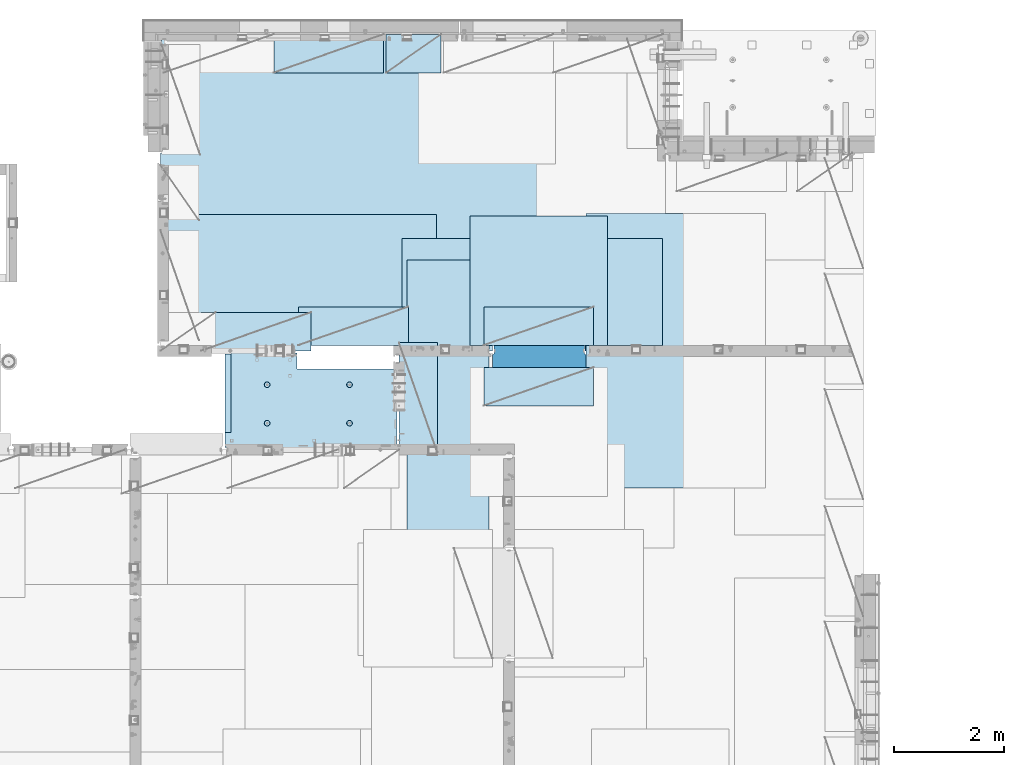
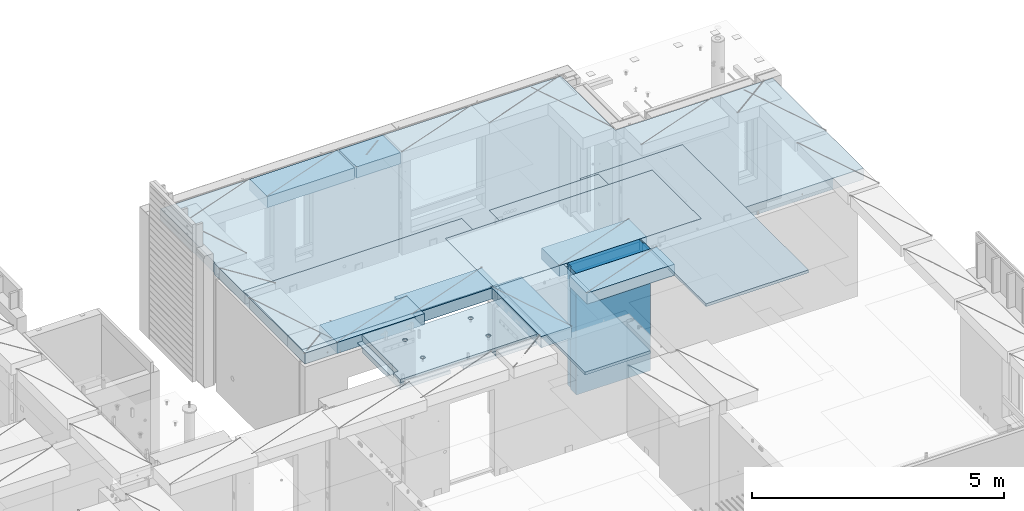
# One storey, part 178 of 309: 13 plates, 2 slabs, 14 elements without a shape of their own.
"""IFC2X3 building model written with IfcOpenShell, lengths in millimetres."""

from ifc_helpers import new_model, si_unit, frame, origin_with_axes, place, context, subcontext, project, spatial, faceted_brep, material, type_object, element, aggregate, save


model = new_model("IFC2X3")

# Units and contexts
model_context = context("Model", 3, precision=1e-05, world=origin_with_axes())
body_context = subcontext(model_context, "Body", "Model", "MODEL_VIEW")
ifc_project = project(units=[si_unit("LENGTHUNIT", "METRE", prefix="MILLI"), si_unit("AREAUNIT", "SQUARE_METRE"), si_unit("VOLUMEUNIT", "CUBIC_METRE"), si_unit("MASSUNIT", "GRAM", prefix="KILO"), si_unit("TIMEUNIT", "SECOND"), si_unit("PLANEANGLEUNIT", "RADIAN"), si_unit("SOLIDANGLEUNIT", "STERADIAN"), si_unit("THERMODYNAMICTEMPERATUREUNIT", "DEGREE_CELSIUS"), si_unit("LUMINOUSINTENSITYUNIT", "LUMEN")], contexts=[model_context])

# Site, building, storey
site_placement = place(None, origin_with_axes())
site = spatial("IfcSite", under=ifc_project, at=site_placement, CompositionType="ELEMENT")
building_placement = place(site_placement, origin_with_axes())
building = spatial("IfcBuilding", under=site, at=building_placement, CompositionType="ELEMENT")
storey_placement = place(building_placement, origin_with_axes())
storey = spatial("IfcBuildingStorey", under=building, at=storey_placement, Name="7", CompositionType="ELEMENT", Elevation=0.0)

# Assembly, slab
assembly_1_placement = place(storey_placement, origin_with_axes())
assembly_1 = element("IfcElementAssembly", 1, at=assembly_1_placement, inside=storey, AssemblyPlace="NOTDEFINED", PredefinedType="REINFORCEMENT_UNIT")
ifc_material_1 = material(Name="CONCRETE/C25/30")
slab_type_1 = type_object("IfcSlabType", PredefinedType="NOTDEFINED")
slab_1_placement = place(assembly_1_placement, frame((26570.0059390845, 15220.0026483125, 102620.0), z_axis=(-0.999999999997437, -2.26400000064461e-06, 0.0), x_axis=(-1.19799915409591e-06, 0.999999999999282, 0.0)))
slab_1 = element("IfcSlab", 2, at=slab_1_placement, type_object=slab_type_1, material=ifc_material_1, PredefinedType="FLOOR", context=body_context, shape_type="Brep", body=[
    faceted_brep([(260.000036693442, 30.0, 20.0001116859203), (260.00040878505, 30.0, 210.00282380305), (760.000392750888, 30.0, 210.001882803081), (760.000035167954, 30.0, 20.0003241859195), (259.999997532928, 50.0008466322761, 0.000110715616756352), (259.999997531775, 130.0, 4.72937244921923e-11), (260.00040878505, 130.0, 210.00282380305), (260.00003669344, 50.0008466322906, 20.0001116859239), (760.000392750888, 130.0, 210.001882803081), (759.999997530887, 50.0009701322706, 0.00188280345173553), (760.000035167954, 50.0009701322851, 20.0003241859267), (759.999997530887, 130.0, 1.4915713109076e-10), (0.0, 130.0, -1.81898940354586e-12), (0.0, 50.0007830199902, -3.63797880709171e-12), (2.23492861550767e-06, 50.0007830199902, 20.0000012144774), (0.00314200731554592, 50.0009709416772, 1679.99820316408), (0.00316042736994859, 130.0, 1679.99820316404), (20.0042037197236, 50.0007871208509, 20.0000019346335), (20.0050448999082, 50.0009732451872, 1679.9981655205), (20.0051981998968, 30.0, 1979.99816552074), (210.003723882246, 30.0, 1979.99780794351), (210.003159282247, 30.0, 1679.99780794404), (20.0050448999027, 30.0, 1679.9981655205), (20.0057858500695, 50.0011356208415, 3129.99855788155), (0.00588817475545511, 50.0011356208415, 3129.99536132812), (0.00371018100122456, 50.0010050132987, 1979.99820316354), (20.0051981998986, 50.0010068401461, 1979.99816552074), (0.0, -49.9992169800098, -3.63797880709171e-12), (0.0, -130.0, -3.63797880709171e-12), (0.00588817475545511, -130.0, 3129.99536132812), (0.00588817475545511, -49.9988643791585, 3129.99536132812), (2.27349282795331e-05, -49.9992169800098, 20.000001214441), (1700.00578510373, 9.99999999994179, 3129.99536132812), (270.007324709519, 9.99999999994179, 3129.99536132812), (270.007273993393, 9.99999999994179, 3014.99280776216), (1700.0058891816, 9.99999999994179, 3014.99217713277), (1700.00588013352, 9.99999999994179, 3024.99005271558), (270.007273993393, -130.000000000058, 3014.99280776216), (270.007324709519, -130.0, 3129.99536132812), (1720.00727399273, -130.000000000058, 3014.99216831216), (1720.00727399273, -49.9988643791585, 3014.99216831216), (1700.0058891816, -49.9988643791585, 3014.99217713277), (1720.00696350816, 50.0011356208415, 1820.00270203459), (1720.00507313573, 130.0, 1820.00270203815), (1720.00548380367, 130.0, 2629.9953613439), (1720.00479630696, 50.0011356208415, 2629.99536134425), (1700.00697064704, 50.0011356208415, 1820.00273967458), (1700.00623760369, 50.0011356208415, 2629.99539898154), (1700.00697064704, -49.9988643791585, 1820.00273967458), (1700.00623760369, 30.0, 2629.99539898154), (1700.00578510373, 30.0, 3129.99535793147), (1510.00479630733, 130.0, 2629.99575656425), (1510.00479630733, 30.0, 2629.99575656425), (1510.00573730659, 130.0, 3129.99536132812), (1510.00573730659, 30.0, 3129.99536134176), (0.00588817475545511, 130.0, 3129.99536132812), (20.0057858500695, -49.9988643791585, 3129.99855788155), (0.00372479000361636, 130.0, 1979.99820316351), (210.003723882246, 130.0, 1979.99780794351), (210.003159282247, 130.0, 1679.99780794404), (20.0042037196527, -49.9988643791585, 20.0000019345935), (20.0041864226587, -49.9992128791491, 7.34271452529356e-07), (1429.99419217423, -49.9988643791585, 20.0006089333838), (1429.99420067423, -49.9988643791585, 0.000608933383773547), (1429.99735169022, -130.0, 7.40013310860377e-05), (458.262860973307, -110.000000000015, 813.90255309167), (472.201273869185, -110.000000000015, 821.004529187678), (483.262860973307, -110.000000000015, 832.066116291804), (490.364837069317, -110.000000000015, 846.004529187678), (492.812011254558, -110.000000000015, 861.455378906427), (490.364837069317, -110.000000000015, 876.906228625172), (483.262860973307, -110.000000000015, 890.844641521049), (472.201273869185, -110.000000000015, 901.906228625176), (458.262860973306, -110.000000000015, 909.008204721184), (442.81201125456, -110.000000000015, 911.455378906427), (427.361161535811, -110.000000000015, 909.008204721184), (413.422748639936, -110.000000000015, 901.906228625176), (402.361161535813, -110.000000000015, 890.844641521046), (395.259185439802, -110.000000000015, 876.906228625176), (392.81201125456, -110.000000000015, 861.455378906427), (395.259185439802, -110.000000000015, 846.004529187681), (402.361161535813, -110.000000000015, 832.0661162918), (413.422748639936, -110.000000000015, 821.004529187678), (427.361161535813, -110.000000000015, 813.90255309167), (442.812011254558, -110.000000000015, 811.455378906427), (458.965172324157, -130.0, 811.741061009179), (442.812011254558, -130.0, 809.182651633699), (473.537149442574, -130.0, 819.165854200462), (485.101535960521, -130.0, 830.730240718414), (492.526329151806, -130.0, 845.302217836826), (495.084738527285, -130.0, 861.45537890643), (492.526329151804, -130.0, 877.608539976027), (485.101535960521, -130.0, 892.180517094443), (473.537149442574, -130.0, 903.744903612387), (458.965172324157, -130.0, 911.16969680367), (442.81201125456, -130.0, 913.728106179151), (426.658850184962, -130.0, 911.169696803674), (412.086873066544, -130.0, 903.744903612391), (400.522486548598, -130.0, 892.180517094443), (393.097693357315, -130.0, 877.608539976027), (390.539283981834, -130.0, 861.455378906427), (393.097693357317, -130.0, 845.302217836826), (400.522486548598, -130.0, 830.730240718414), (412.086873066544, -130.0, 819.165854200462), (426.658850184962, -130.0, 811.741061009183), (1158.26361347154, -110.000000000058, 2313.90608356011), (1172.20202636741, -110.000000000058, 2321.00805965612), (1183.26361347154, -110.000000000058, 2332.06964676024), (1190.36558956755, -110.000000000058, 2346.00805965611), (1192.81276375279, -110.000000000058, 2361.45890937486), (1190.36558956755, -110.000000000058, 2376.90975909361), (1183.26361347154, -110.000000000058, 2390.84817198949), (1172.20202636741, -110.000000000058, 2401.90975909361), (1158.26361347154, -110.000000000058, 2409.01173518962), (1142.81276375279, -110.000000000058, 2411.45890937487), (1127.36191403404, -110.000000000058, 2409.01173518962), (1113.42350113817, -110.000000000058, 2401.90975909361), (1102.36191403404, -110.000000000058, 2390.84817198948), (1095.25993793803, -110.000000000058, 2376.90975909361), (1092.81276375279, -110.000000000058, 2361.45890937486), (1095.25993793803, -110.000000000058, 2346.00805965612), (1102.36191403404, -110.000000000058, 2332.06964676024), (1113.42350113817, -110.000000000058, 2321.00805965611), (1127.36191403405, -110.000000000058, 2313.90608356011), (1142.81276375279, -110.000000000058, 2311.45890937486), (1158.96592482239, -130.000000000044, 2311.74459147762), (1142.81276375279, -130.000000000044, 2309.18618210214), (1173.5379019408, -130.000000000044, 2319.1693846689), (1185.10228845875, -130.000000000044, 2330.73377118685), (1192.52708165004, -130.000000000044, 2345.30574830526), (1195.08549102551, -130.000000000044, 2361.45890937486), (1192.52708165004, -130.000000000044, 2377.61207044447), (1185.10228845875, -130.000000000044, 2392.18404756288), (1173.5379019408, -130.000000000044, 2403.74843408083), (1158.96592482239, -130.000000000044, 2411.17322727211), (1142.81276375279, -130.000000000044, 2413.73163664759), (1126.65960268319, -130.000000000044, 2411.17322727211), (1112.08762556478, -130.000000000044, 2403.74843408083), (1100.52323904683, -130.000000000044, 2392.18404756287), (1093.09844585554, -130.000000000044, 2377.61207044447), (1090.54003648007, -130.000000000044, 2361.45890937486), (1093.09844585555, -130.000000000044, 2345.30574830526), (1100.52323904683, -130.000000000044, 2330.73377118685), (1112.08762556478, -130.000000000044, 2319.1693846689), (1126.65960268319, -130.000000000044, 2311.74459147762), (1158.26322681425, -110.000000000029, 813.902566246979), (1172.20163971013, -110.000000000029, 821.004542342987), (1183.26322681425, -110.000000000029, 832.066129447114), (1190.36520291026, -110.000000000029, 846.004542342987), (1192.8123770955, -110.000000000029, 861.455392061736), (1190.36520291026, -110.000000000029, 876.906241780482), (1183.26322681425, -110.000000000029, 890.844654676363), (1172.20163971012, -110.000000000029, 901.906241780485), (1158.26322681425, -110.000000000029, 909.008217876493), (1142.8123770955, -110.000000000029, 911.455392061736), (1127.36152737675, -110.000000000029, 909.008217876493), (1113.42311448088, -110.000000000029, 901.906241780485), (1102.36152737675, -110.000000000029, 890.844654676359), (1095.25955128074, -110.000000000029, 876.906241780485), (1092.8123770955, -110.000000000029, 861.45539206174), (1095.25955128074, -110.000000000029, 846.004542342991), (1102.36152737675, -110.000000000029, 832.06612944711), (1113.42311448088, -110.000000000029, 821.004542342987), (1127.36152737675, -110.000000000029, 813.902566246979), (1142.8123770955, -110.000000000029, 811.455392061736), (1158.9655381651, -130.000000000029, 811.741074164489), (1142.8123770955, -130.000000000029, 809.182664789012), (1173.53751528352, -130.000000000029, 819.165867355772), (1185.10190180146, -130.000000000029, 830.730253873724), (1192.52669499275, -130.000000000029, 845.302230992136), (1195.08510436823, -130.000000000029, 861.45539206174), (1192.52669499275, -130.000000000029, 877.608553131337), (1185.10190180146, -130.000000000029, 892.180530249756), (1173.53751528351, -130.000000000029, 903.744916767697), (1158.9655381651, -130.000000000029, 911.16970995898), (1142.8123770955, -130.000000000029, 913.728119334461), (1126.6592160259, -130.000000000029, 911.169709958984), (1112.08723890749, -130.000000000029, 903.7449167677), (1100.52285238954, -130.000000000029, 892.180530249752), (1093.09805919825, -130.000000000029, 877.608553131337), (1090.53964982277, -130.000000000015, 861.455392061736), (1093.09805919826, -130.000000000015, 845.302230992136), (1100.52285238954, -130.000000000015, 830.730253873724), (1112.08723890749, -130.000000000015, 819.165867355776), (1126.6592160259, -130.000000000015, 811.741074164493), (458.263613472778, -110.000000000058, 2313.90740096011), (472.202026368655, -110.000000000058, 2321.00937705611), (483.263613472776, -110.000000000058, 2332.07096416024), (490.365589568788, -110.000000000058, 2346.00937705611), (492.812763754029, -110.000000000058, 2361.46022677486), (490.365589568788, -110.000000000058, 2376.91107649361), (483.263613472778, -110.000000000058, 2390.84948938949), (472.202026368655, -110.000000000058, 2401.91107649361), (458.263613472776, -110.000000000058, 2409.01305258962), (442.812763754029, -110.000000000058, 2411.46022677486), (427.361914035282, -110.000000000058, 2409.01305258962), (413.423501139407, -110.000000000058, 2401.91107649361), (402.361914035284, -110.000000000058, 2390.84948938949), (395.259937939272, -110.000000000058, 2376.91107649361), (392.812763754031, -110.000000000058, 2361.46022677486), (395.259937939272, -110.000000000058, 2346.00937705612), (402.361914035284, -110.000000000058, 2332.07096416024), (413.423501139407, -110.000000000058, 2321.00937705611), (427.361914035284, -110.000000000058, 2313.90740096011), (442.812763754029, -110.000000000058, 2311.46022677486), (458.965924823628, -130.000000000029, 2311.74590887762), (442.812763754029, -130.000000000029, 2309.18749950214), (473.537901942043, -130.000000000029, 2319.1707020689), (485.10228845999, -130.000000000029, 2330.73508858685), (492.527081651273, -130.000000000029, 2345.30706570526), (495.085491026754, -130.000000000029, 2361.46022677486), (492.527081651273, -130.000000000029, 2377.61338784446), (485.102288459992, -130.000000000029, 2392.18536496288), (473.537901942043, -130.000000000029, 2403.74975148082), (458.965924823628, -130.000000000029, 2411.1745446721), (442.812763754031, -130.000000000029, 2413.73295404758), (426.659602684433, -130.000000000029, 2411.17454467211), (412.087625566017, -130.000000000029, 2403.74975148082), (400.523239048071, -130.000000000029, 2392.18536496288), (393.098445856787, -130.000000000029, 2377.61338784446), (390.540036481307, -130.000000000029, 2361.46022677486), (393.098445856789, -130.000000000029, 2345.30706570526), (400.523239048067, -130.000000000029, 2330.73508858685), (412.087625566017, -130.000000000029, 2319.17070206891), (426.659602684433, -130.000000000029, 2311.74590887762), (1720.00603595581, -130.000000000029, 1820.00270203634), (1430.00077693619, -130.000000000044, 1820.00324782623), (1720.00719416424, -49.9988643791585, 1820.00270203415), (1430.00077693619, 129.999999999985, 1820.00324782623), (1429.99416747423, 50.0011356208415, 20.0006089334311), (1429.99417597423, 50.0011356208415, 0.000608933431067271), (1429.99735169022, 130.0, 2.80124368146062e-10), (20.0041864225386, 50.0007871208509, -3.03407432511449e-09)], [[[0, 1, 2, 3]], [[4, 5, 6, 1, 0, 7]], [[8, 2, 1, 6]], [[9, 10, 3, 2, 8, 11]], [[12, 13, 14, 15, 16]], [[14, 17, 18, 15]], [[19, 20, 21, 22]], [[23, 24, 25, 26]], [[27, 28, 29, 30, 31]], [[32, 33, 34, 35, 36]], [[37, 34, 33, 38]], [[35, 34, 37, 39, 40, 41]], [[42, 43, 44, 45]], [[46, 42, 45, 47]], [[32, 36, 35, 41, 48, 46, 47, 49, 50]], [[45, 44, 51, 52, 49, 47]], [[53, 54, 52, 51]], [[49, 52, 54, 50]], [[53, 55, 24, 23, 56, 30, 29, 38, 33, 32, 50, 54]], [[24, 55, 57, 25]], [[58, 20, 19, 26, 25, 57]], [[59, 21, 20, 58]], [[16, 15, 18, 22, 21, 59]], [[17, 60, 56, 23, 26, 19, 22, 18]], [[31, 30, 56, 60]], [[61, 27, 31, 60, 62, 63]], [[28, 27, 61, 63, 64]], [[65, 66, 67, 68, 69, 70, 71, 72, 73, 74, 75, 76, 77, 78, 79, 80, 81, 82, 83, 84]], [[85, 65, 84, 86]], [[87, 66, 65, 85]], [[88, 67, 66, 87]], [[89, 68, 67, 88]], [[90, 69, 68, 89]], [[91, 70, 69, 90]], [[92, 71, 70, 91]], [[93, 72, 71, 92]], [[94, 73, 72, 93]], [[95, 74, 73, 94]], [[96, 75, 74, 95]], [[97, 76, 75, 96]], [[98, 77, 76, 97]], [[99, 78, 77, 98]], [[100, 79, 78, 99]], [[101, 80, 79, 100]], [[102, 81, 80, 101]], [[103, 82, 81, 102]], [[104, 83, 82, 103]], [[86, 84, 83, 104]], [[105, 106, 107, 108, 109, 110, 111, 112, 113, 114, 115, 116, 117, 118, 119, 120, 121, 122, 123, 124]], [[125, 105, 124, 126]], [[127, 106, 105, 125]], [[128, 107, 106, 127]], [[129, 108, 107, 128]], [[130, 109, 108, 129]], [[131, 110, 109, 130]], [[132, 111, 110, 131]], [[133, 112, 111, 132]], [[134, 113, 112, 133]], [[135, 114, 113, 134]], [[136, 115, 114, 135]], [[137, 116, 115, 136]], [[138, 117, 116, 137]], [[139, 118, 117, 138]], [[140, 119, 118, 139]], [[141, 120, 119, 140]], [[142, 121, 120, 141]], [[143, 122, 121, 142]], [[144, 123, 122, 143]], [[126, 124, 123, 144]], [[145, 146, 147, 148, 149, 150, 151, 152, 153, 154, 155, 156, 157, 158, 159, 160, 161, 162, 163, 164]], [[165, 145, 164, 166]], [[167, 146, 145, 165]], [[168, 147, 146, 167]], [[169, 148, 147, 168]], [[170, 149, 148, 169]], [[171, 150, 149, 170]], [[172, 151, 150, 171]], [[173, 152, 151, 172]], [[174, 153, 152, 173]], [[175, 154, 153, 174]], [[176, 155, 154, 175]], [[177, 156, 155, 176]], [[178, 157, 156, 177]], [[179, 158, 157, 178]], [[180, 159, 158, 179]], [[181, 160, 159, 180]], [[182, 161, 160, 181]], [[183, 162, 161, 182]], [[184, 163, 162, 183]], [[166, 164, 163, 184]], [[185, 186, 187, 188, 189, 190, 191, 192, 193, 194, 195, 196, 197, 198, 199, 200, 201, 202, 203, 204]], [[205, 185, 204, 206]], [[207, 186, 185, 205]], [[208, 187, 186, 207]], [[209, 188, 187, 208]], [[210, 189, 188, 209]], [[211, 190, 189, 210]], [[212, 191, 190, 211]], [[213, 192, 191, 212]], [[214, 193, 192, 213]], [[215, 194, 193, 214]], [[216, 195, 194, 215]], [[217, 196, 195, 216]], [[218, 197, 196, 217]], [[219, 198, 197, 218]], [[220, 199, 198, 219]], [[221, 200, 199, 220]], [[222, 201, 200, 221]], [[223, 202, 201, 222]], [[224, 203, 202, 223]], [[206, 204, 203, 224]], [[225, 39, 37, 38, 29, 28, 64, 226], [223, 222, 221, 220, 219, 218, 217, 216, 215, 214, 213, 212, 211, 210, 209, 208, 207, 205, 206, 224], [183, 182, 181, 180, 179, 178, 177, 176, 175, 174, 173, 172, 171, 170, 169, 168, 167, 165, 166, 184], [143, 142, 141, 140, 139, 138, 137, 136, 135, 134, 133, 132, 131, 130, 129, 128, 127, 125, 126, 144], [103, 102, 101, 100, 99, 98, 97, 96, 95, 94, 93, 92, 91, 90, 89, 88, 87, 85, 86, 104]], [[40, 39, 225, 227]], [[41, 40, 227, 48]], [[225, 226, 228, 43, 42, 46, 48, 227]], [[64, 63, 62, 229, 230, 231, 228, 226]], [[231, 230, 9, 11]], [[6, 5, 12, 16, 59, 58, 57, 55, 53, 51, 44, 43, 228, 231, 11, 8]], [[232, 13, 12, 5, 4]], [[17, 14, 13, 232, 4, 7]], [[229, 62, 60, 17, 7, 0, 3, 10]], [[230, 229, 10, 9]]]),
])
aggregate(assembly_1, [slab_1])

assembly_2_placement = place(storey_placement, origin_with_axes())
assembly_2 = element("IfcElementAssembly", 3, at=assembly_2_placement, inside=storey, AssemblyPlace="NOTDEFINED", PredefinedType="REINFORCEMENT_UNIT")
ifc_material_2 = material(Name="CONCRETE/C30/37")
slab_type_2 = type_object("IfcSlabType", PredefinedType="NOTDEFINED")
slab_2_placement = place(assembly_2_placement, frame((22310.0, 16980.0, 102595.0), z_axis=(0.0, 1.0, 0.0), x_axis=(1.0, 0.0, 0.0)))
slab_2 = element("IfcSlab", 4, at=slab_2_placement, type_object=slab_type_2, material=ifc_material_2, PredefinedType="FLOOR", context=body_context, shape_type="Brep", body=[
    faceted_brep([(4369.99914550782, -135.0, 99.9999987875526), (4369.99914550782, 135.0, 99.9999987875526), (4369.99914550782, 135.0, 0.0), (4369.99914550782, -135.0, 0.0), (4169.99914550781, -135.0, 99.9997253417969), (4169.99914550781, 135.0, 99.9997253417969), (2489.99914550781, -135.0, 0.0), (2489.99914550781, 135.0, 0.0), (2489.99914550781, 135.0, 99.9997253417969), (2489.99914550781, -135.0, 99.9997253417969), (1.81898940354586e-12, -135.0, 1.81898940354586e-12), (1.81898940354586e-12, 135.0, 1.81898940354586e-12), (-39.9985427856445, -135.0, -0.0037095642182976), (-39.9985427856445, 135.0, -0.0037095642182976), (-40.0, -135.0, 3600.00048828125), (-40.0, 135.0, 3600.00048828125), (-20.0, -135.0, 3600.0), (-20.0, 135.0, 3600.0), (-20.0, -135.0, 5760.0), (-20.0, 135.0, 5760.0), (9149.9990234375, -135.0, 5760.0), (9149.9990234375, 135.0, 5760.0), (9149.9990234375, -135.0, 3600.00073242188), (9149.9990234375, 135.0, 3600.00073242188), (12750.0, -135.0, 3599.9951171875), (12750.0, 135.0, 3599.9951171875), (12750.0, -135.0, 0.0), (12750.0, 135.0, 0.0), (7685.0006429507, -135.0, 0.0), (7685.0006429507, 135.0, 0.0), (7685.0006429507, -135.0, 99.9996630941932), (7685.0006429507, 135.0, 99.9996630941932), (5999.99954431789, -135.0, 99.9996630941932), (5999.99954431789, 135.0, 99.9996630941932), (5999.99954431789, -135.0, 0.0), (5999.99954431789, 135.0, 0.0), (2730.00000000001, 135.0, 99.9997253417969), (2730.00000000001, -135.0, 99.9997253417969)], [[[0, 1, 2, 3]], [[4, 5, 1, 0]], [[6, 7, 8, 9]], [[10, 11, 7, 6]], [[10, 12, 13, 11]], [[12, 14, 15, 13]], [[14, 16, 17, 15]], [[16, 18, 19, 17]], [[18, 20, 21, 19]], [[20, 22, 23, 21]], [[22, 24, 25, 23]], [[24, 26, 27, 25]], [[27, 26, 28, 29]], [[30, 31, 29, 28]], [[32, 33, 31, 30]], [[34, 35, 33, 32]], [[35, 34, 3, 2]], [[36, 8, 7, 11, 13, 15, 17, 19, 21, 23, 25, 27, 29, 31, 33, 35, 2, 1, 5]], [[37, 9, 8, 36, 5, 4]], [[34, 32, 30, 28, 26, 24, 22, 20, 18, 16, 14, 12, 10, 6, 9, 37, 4, 0, 3]]]),
])

# Assembly, plate
assembly_3_placement = place(storey_placement, origin_with_axes())
assembly_3 = element("IfcElementAssembly", 5, at=assembly_3_placement, inside=storey, Name="Steel Assembly", AssemblyPlace="NOTDEFINED", PredefinedType="NOTDEFINED")
ifc_material_3 = material()
plate_type_1 = type_object("IfcPlateType", PredefinedType="NOTDEFINED")
plate_1_placement = place(assembly_3_placement, frame((22289.9998779297, 19460.0009765625, 102695.1), z_axis=(1.0, 0.0, 0.0), x_axis=(0.0, -1.0, 0.0)))
plate_1 = element("IfcPlate", 6, at=plate_1_placement, type_object=plate_type_1, material=ifc_material_3, context=body_context, shape_type="Brep", body=[
    faceted_brep([(0.0, -35.0, 0.0), (0.0, -35.0, 5000.0), (0.0, 35.0, 5000.0), (0.0, 35.0, 0.0), (2349.99951171875, -35.0, 5000.0), (2349.99951171875, 35.0, 5000.0), (2350.0, -35.0, 0.0), (2350.0, 35.0, 0.0)], [[[0, 1, 2, 3]], [[1, 4, 5, 2]], [[4, 6, 7, 5]], [[6, 0, 3, 7]], [[5, 7, 3, 2]], [[6, 4, 1, 0]]]),
])
aggregate(assembly_3, [plate_1])

assembly_4_placement = place(storey_placement, origin_with_axes())
assembly_4 = element("IfcElementAssembly", 7, at=assembly_4_placement, inside=storey, Name="Steel Assembly", AssemblyPlace="NOTDEFINED", PredefinedType="NOTDEFINED")
plate_2_placement = place(assembly_4_placement, frame((27902.5, 19430.0, 102695.1), z_axis=(1.0, 0.0, 0.0), x_axis=(0.0, -1.0, 0.0)))
plate_2 = element("IfcPlate", 8, at=plate_2_placement, type_object=plate_type_1, material=ifc_material_3, Name="1/2", context=body_context, shape_type="Brep", body=[
    faceted_brep([(0.0, -35.0, 0.0), (0.0, -35.0, 2500.0), (0.0, 35.0, 2500.0), (0.0, 35.0, 0.0), (2349.99951171875, -35.0, 2500.0), (2349.99951171875, 35.0, 2500.0), (2350.0, -35.0, 0.0), (2350.0, 35.0, 0.0)], [[[0, 1, 2, 3]], [[1, 4, 5, 2]], [[4, 6, 7, 5]], [[6, 0, 3, 7]], [[5, 7, 3, 2]], [[6, 4, 1, 0]]]),
])
aggregate(assembly_4, [plate_2])

assembly_5_placement = place(storey_placement, origin_with_axes())
assembly_5 = element("IfcElementAssembly", 9, at=assembly_5_placement, inside=storey, Name="Steel Assembly", AssemblyPlace="NOTDEFINED", PredefinedType="NOTDEFINED")
plate_3_placement = place(assembly_5_placement, frame((32360.0, 19480.0, 102695.1), z_axis=(0.0, -1.0, 0.0), x_axis=(-1.0, 3.00000001838171e-08, 0.0)))
plate_3 = element("IfcPlate", 10, at=plate_3_placement, type_object=plate_type_1, material=ifc_material_3, context=body_context, shape_type="Brep", body=[
    faceted_brep([(0.0, -35.0, 0.0), (0.0, -35.0, 5000.0), (0.0, 35.0, 5000.0), (0.0, 35.0, 0.0), (2349.99951171875, -35.0, 5000.0), (2349.99951171875, 35.0, 5000.0), (2350.0, -35.0, 0.0), (2350.0, 35.0, 0.0)], [[[0, 1, 2, 3]], [[1, 4, 5, 2]], [[4, 6, 7, 5]], [[6, 0, 3, 7]], [[5, 7, 3, 2]], [[6, 4, 1, 0]]]),
])
aggregate(assembly_5, [plate_3])

assembly_6_placement = place(storey_placement, origin_with_axes())
assembly_6 = element("IfcElementAssembly", 11, at=assembly_6_placement, inside=storey, Name="Steel Assembly", AssemblyPlace="NOTDEFINED", PredefinedType="NOTDEFINED")
plate_type_2 = type_object("IfcPlateType", PredefinedType="NOTDEFINED")
plate_4_placement = place(assembly_6_placement, frame((28250.0000122641, 18630.0, 102695.100000381), z_axis=(0.0, -1.0, 0.0), x_axis=(-1.0, 3.00000001838171e-08, 0.0)))
plate_4 = element("IfcPlate", 12, at=plate_4_placement, type_object=plate_type_2, material=ifc_material_3, context=body_context, shape_type="Brep", body=[
    faceted_brep([(0.0, -35.0, 0.0), (0.0, -35.0, 5000.0), (0.0, 35.0, 5000.0), (0.0, 35.0, 0.0), (1499.99951171875, -35.0, 5000.0), (1499.99951171875, 35.0, 5000.0), (1500.0, -35.0, 0.0), (1500.0, 35.0, 0.0)], [[[0, 1, 2, 3]], [[1, 4, 5, 2]], [[4, 6, 7, 5]], [[6, 0, 3, 7]], [[5, 7, 3, 2]], [[6, 4, 1, 0]]]),
])
aggregate(assembly_6, [plate_4])

assembly_7_placement = place(storey_placement, origin_with_axes())
assembly_7 = element("IfcElementAssembly", 13, at=assembly_7_placement, inside=storey, Name="Steel Assembly", AssemblyPlace="NOTDEFINED", PredefinedType="NOTDEFINED")
plate_type_3 = type_object("IfcPlateType", PredefinedType="NOTDEFINED")
plate_5_placement = place(assembly_7_placement, frame((26330.0, 22740.0001220703, 102595.3), z_axis=(0.0, -1.0, 0.0), x_axis=(-1.0, 3.00000001838171e-08, 0.0)))
plate_5 = element("IfcPlate", 14, at=plate_5_placement, type_object=plate_type_3, material=ifc_material_3, Name="RE1", context=body_context, shape_type="Brep", body=[
    faceted_brep([(1.81898940354586e-12, -135.0, 1.81898940354586e-12), (0.0, -135.0, 699.999999999996), (0.0, 135.0, 699.999999999996), (1.81898940354586e-12, 135.0, 1.81898940354586e-12), (1999.99951171875, -135.0, 699.999999999993), (1999.99951171875, 135.0, 699.999999999993), (2000.0, -135.0, -3.63797880709171e-12), (2000.0, 135.0, -3.63797880709171e-12)], [[[0, 1, 2, 3]], [[1, 4, 5, 2]], [[4, 6, 7, 5]], [[6, 0, 3, 7]], [[5, 7, 3, 2]], [[6, 4, 1, 0]]]),
])
aggregate(assembly_7, [plate_5])

assembly_8_placement = place(storey_placement, origin_with_axes())
assembly_8 = element("IfcElementAssembly", 15, at=assembly_8_placement, inside=storey, Name="Steel Assembly", AssemblyPlace="NOTDEFINED", PredefinedType="NOTDEFINED")
plate_6_placement = place(assembly_8_placement, frame((27375.0, 22740.0000000707, 102595.3), z_axis=(0.0, -1.0, 0.0), x_axis=(-1.0, 3.00000001838171e-08, 0.0)))
plate_6 = element("IfcPlate", 16, at=plate_6_placement, type_object=plate_type_3, material=ifc_material_3, Name="RE1_1/2", context=body_context, shape_type="Brep", body=[
    faceted_brep([(1.81898940354586e-12, -135.0, 1.81898940354586e-12), (0.0, -135.0, 699.999999999996), (0.0, 135.0, 699.999999999996), (1.81898940354586e-12, 135.0, 1.81898940354586e-12), (999.99951171875, -135.0, 700.0), (999.99951171875, 135.0, 700.0), (1000.0, -135.0, 0.0), (1000.0, 135.0, 0.0)], [[[0, 1, 2, 3]], [[1, 4, 5, 2]], [[4, 6, 7, 5]], [[6, 0, 3, 7]], [[5, 7, 3, 2]], [[6, 4, 1, 0]]]),
])
aggregate(assembly_8, [plate_6])

assembly_9_placement = place(storey_placement, origin_with_axes())
assembly_9 = element("IfcElementAssembly", 17, at=assembly_9_placement, inside=storey, Name="Steel Assembly", AssemblyPlace="NOTDEFINED", PredefinedType="NOTDEFINED")
plate_7_placement = place(assembly_9_placement, frame((23010.0008542386, 16980.0001036336, 102595.3), z_axis=(0.0, 1.0, 0.0), x_axis=(1.0, 0.0, 0.0)))
plate_7 = element("IfcPlate", 18, at=plate_7_placement, type_object=plate_type_3, material=ifc_material_3, Name="RE1", context=body_context, shape_type="Brep", body=[
    faceted_brep([(1.81898940354586e-12, -135.0, 1.81898940354586e-12), (0.0, -135.0, 699.999999999996), (0.0, 135.0, 699.999999999996), (1.81898940354586e-12, 135.0, 1.81898940354586e-12), (1999.99951171875, -135.0, 699.999999999993), (1999.99951171875, 135.0, 699.999999999993), (2000.0, -135.0, -3.63797880709171e-12), (2000.0, 135.0, -3.63797880709171e-12)], [[[0, 1, 2, 3]], [[1, 4, 5, 2]], [[4, 6, 7, 5]], [[6, 0, 3, 7]], [[5, 7, 3, 2]], [[6, 4, 1, 0]]]),
])
aggregate(assembly_9, [plate_7])

assembly_10_placement = place(storey_placement, origin_with_axes())
assembly_10 = element("IfcElementAssembly", 19, at=assembly_10_placement, inside=storey, Name="Steel Assembly", AssemblyPlace="NOTDEFINED", PredefinedType="NOTDEFINED")
plate_8_placement = place(assembly_10_placement, frame((30152.4991457614, 16679.9998963664, 102595.3), z_axis=(0.0, -1.0, 0.0), x_axis=(-1.0, 3.00000001838171e-08, 0.0)))
plate_8 = element("IfcPlate", 20, at=plate_8_placement, type_object=plate_type_3, material=ifc_material_3, Name="RE1", context=body_context, shape_type="Brep", body=[
    faceted_brep([(1.81898940354586e-12, -135.0, 1.81898940354586e-12), (0.0, -135.0, 699.999999999996), (0.0, 135.0, 699.999999999996), (1.81898940354586e-12, 135.0, 1.81898940354586e-12), (1999.99951171875, -135.0, 699.999999999993), (1999.99951171875, 135.0, 699.999999999993), (2000.0, -135.0, -3.63797880709171e-12), (2000.0, 135.0, -3.63797880709171e-12)], [[[0, 1, 2, 3]], [[1, 4, 5, 2]], [[4, 6, 7, 5]], [[6, 0, 3, 7]], [[5, 7, 3, 2]], [[6, 4, 1, 0]]]),
])
aggregate(assembly_10, [plate_8])

assembly_11_placement = place(storey_placement, origin_with_axes())
assembly_11 = element("IfcElementAssembly", 21, at=assembly_11_placement, inside=storey, Name="Steel Assembly", AssemblyPlace="NOTDEFINED", PredefinedType="NOTDEFINED")
plate_9_placement = place(assembly_11_placement, frame((28152.5008542386, 17080.0001036336, 102595.3), z_axis=(0.0, 1.0, 0.0), x_axis=(1.0, 0.0, 0.0)))
plate_9 = element("IfcPlate", 22, at=plate_9_placement, type_object=plate_type_3, material=ifc_material_3, Name="RE1", context=body_context, shape_type="Brep", body=[
    faceted_brep([(1.81898940354586e-12, -135.0, 1.81898940354586e-12), (0.0, -135.0, 699.999999999996), (0.0, 135.0, 699.999999999996), (1.81898940354586e-12, 135.0, 1.81898940354586e-12), (1999.99951171875, -135.0, 699.999999999993), (1999.99951171875, 135.0, 699.999999999993), (2000.0, -135.0, -3.63797880709171e-12), (2000.0, 135.0, -3.63797880709171e-12)], [[[0, 1, 2, 3]], [[1, 4, 5, 2]], [[4, 6, 7, 5]], [[6, 0, 3, 7]], [[5, 7, 3, 2]], [[6, 4, 1, 0]]]),
])
aggregate(assembly_11, [plate_9])

assembly_12_placement = place(storey_placement, origin_with_axes())
assembly_12 = element("IfcElementAssembly", 23, at=assembly_12_placement, inside=storey, Name="Steel Assembly", AssemblyPlace="NOTDEFINED", PredefinedType="NOTDEFINED")
plate_10_placement = place(assembly_12_placement, frame((24780.0008542386, 17080.0001036336, 102595.3), z_axis=(0.0, 1.0, 0.0), x_axis=(1.0, 0.0, 0.0)))
plate_10 = element("IfcPlate", 24, at=plate_10_placement, type_object=plate_type_3, material=ifc_material_3, Name="RE1", context=body_context, shape_type="Brep", body=[
    faceted_brep([(1.81898940354586e-12, -135.0, 1.81898940354586e-12), (0.0, -135.0, 699.999999999996), (0.0, 135.0, 699.999999999996), (1.81898940354586e-12, 135.0, 1.81898940354586e-12), (1999.99951171875, -135.0, 699.999999999993), (1999.99951171875, 135.0, 699.999999999993), (2000.0, -135.0, -3.63797880709171e-12), (2000.0, 135.0, -3.63797880709171e-12)], [[[0, 1, 2, 3]], [[1, 4, 5, 2]], [[4, 6, 7, 5]], [[6, 0, 3, 7]], [[5, 7, 3, 2]], [[6, 4, 1, 0]]]),
])
aggregate(assembly_12, [plate_10])

assembly_13_placement = place(storey_placement, origin_with_axes())
assembly_13 = element("IfcElementAssembly", 25, at=assembly_13_placement, inside=storey, Name="Steel Assembly", AssemblyPlace="NOTDEFINED", PredefinedType="NOTDEFINED")
plate_11_placement = place(assembly_13_placement, frame((26609.9998779297, 17130.0, 102595.3), z_axis=(1.0, 0.0, 0.0), x_axis=(0.0, -1.0, 0.0)))
plate_11 = element("IfcPlate", 26, at=plate_11_placement, type_object=plate_type_3, material=ifc_material_3, Name="RE1", context=body_context, shape_type="Brep", body=[
    faceted_brep([(1.81898940354586e-12, -135.0, 1.81898940354586e-12), (0.0, -135.0, 699.999999999996), (0.0, 135.0, 699.999999999996), (1.81898940354586e-12, 135.0, 1.81898940354586e-12), (1999.99951171875, -135.0, 699.999999999993), (1999.99951171875, 135.0, 699.999999999993), (2000.0, -135.0, -3.63797880709171e-12), (2000.0, 135.0, -3.63797880709171e-12)], [[[0, 1, 2, 3]], [[1, 4, 5, 2]], [[4, 6, 7, 5]], [[6, 0, 3, 7]], [[5, 7, 3, 2]], [[6, 4, 1, 0]]]),
])
aggregate(assembly_13, [plate_11])

# Plate
plate_type_4 = type_object("IfcPlateType", PredefinedType="NOTDEFINED")
plate_12_placement = place(assembly_2_placement, frame((31402.0004441066, 19019.9993561238, 102725.45), z_axis=(0.0, -1.0, 0.0), x_axis=(-1.0, 3.00000001838171e-08, 0.0)))
plate_12 = element("IfcPlate", 27, at=plate_12_placement, type_object=plate_type_4, material=ifc_material_3, context=body_context, shape_type="Brep", body=[
    faceted_brep([(0.0, -5.0, 0.0), (0.0, -5.0, 1939.99963378906), (0.0, 5.0, 1939.99963378906), (0.0, 5.0, 0.0), (4742.00048828125, -5.0, 1939.99963378906), (4742.00048828125, 5.0, 1939.99963378906), (4742.00048828125, -5.0, 0.0), (4742.00048828125, 5.0, 0.0), (92.0009613037109, -5.0, 0.0), (92.0009613037109, 5.0, 0.0)], [[[0, 1, 2, 3]], [[1, 4, 5, 2]], [[4, 6, 7, 5]], [[6, 8, 9, 7]], [[8, 0, 3, 9]], [[5, 7, 9, 3, 2]], [[8, 6, 4, 1, 0]]]),
])

aggregate(assembly_2, [plate_12, slab_2])

# Assembly, plate
assembly_14_placement = place(storey_placement, origin_with_axes())
assembly_14 = element("IfcElementAssembly", 28, at=assembly_14_placement, inside=storey, Name="Steel Assembly", AssemblyPlace="NOTDEFINED", PredefinedType="NOTDEFINED")
ifc_material_4 = material()
plate_type_5 = type_object("IfcPlateType", PredefinedType="NOTDEFINED")
plate_13_placement = place(assembly_14_placement, frame((28309.9999105288, 16680.0000293051, 101255.600000381), z_axis=(0.0, 1.0, 0.0), x_axis=(1.0, 0.0, 0.0)))
plate_13 = element("IfcPlate", 29, at=plate_13_placement, type_object=plate_type_5, material=ifc_material_4, context=body_context, shape_type="Brep", body=[
    faceted_brep([(29.9999989126591, -1475.0, 243.000885767418), (29.9999989126591, 1475.0, 243.000885767418), (0.0, 1475.0, 230.000886222213), (0.0, -1475.0, 230.000886222213), (30.0000025741901, -1475.0, 399.999635204884), (30.0000025741901, 1475.0, 399.999633789063), (1700.00073242188, -1475.0, 0.0), (0.0, -1475.0, 0.0), (0.0, 1475.0, 0.0), (1700.00073242188, 1475.0, 0.0), (1700.00073242188, 1475.0, 230.001129150391), (1700.00041094652, -1475.0, 230.001129150391), (1670.00041094652, 1475.0, 243.001129150391), (1670.00041094652, -1475.0, 243.001129150391), (1670.00041094652, -1475.0, 399.999633789063), (1670.00041094652, 1475.0, 399.999633789063)], [[[0, 1, 2, 3]], [[4, 5, 1, 0]], [[6, 7, 8, 9]], [[6, 9, 10, 11]], [[11, 10, 12, 13]], [[14, 13, 12, 15]], [[3, 7, 6, 11, 13, 14, 4, 0]], [[8, 7, 3, 2]], [[15, 12, 10, 9, 8, 2, 1, 5]], [[14, 15, 5, 4]]]),
])
aggregate(assembly_14, [plate_13])

save(model, "model.ifc")
